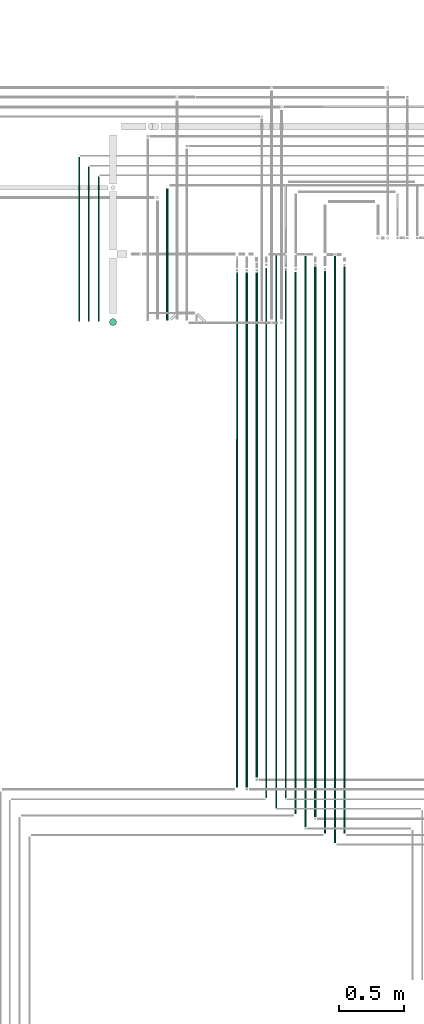
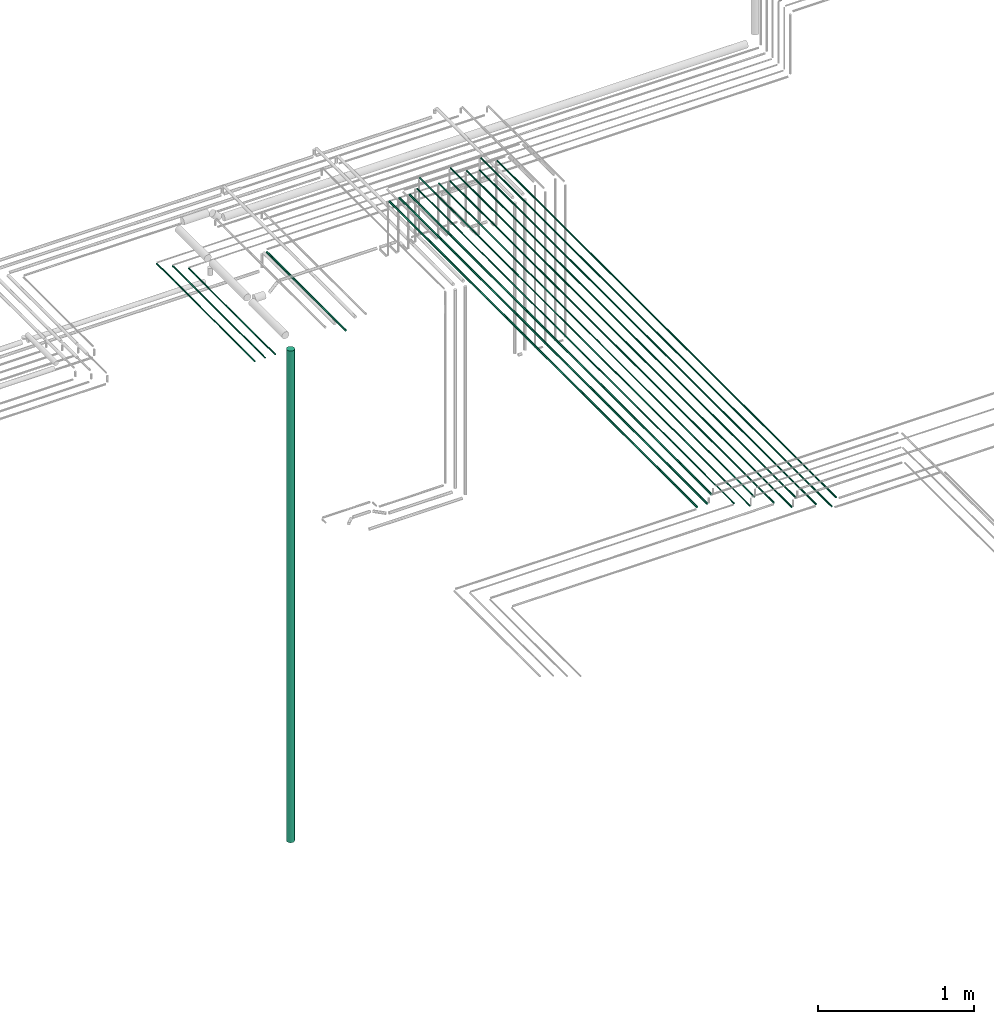
# One storey, part 24 of 65: 17 flow segments.
"""IFC2X3 building model written with IfcOpenShell, lengths in millimetres."""

from ifc_helpers import new_model, entity, si_unit, converted_unit, derived_unit, direction, frame, frame_2d, origin, origin_2d_with_axis, place, context, subcontext, project, spatial, circle, extrude, type_object, element, save


model = new_model("IFC2X3")

# Units and contexts
model_context = context("Model", 3, precision=0.01, world=origin(), true_north=direction((6.12303176911189e-17, 1.0)))
body_context = subcontext(model_context, "Body", "Model", "MODEL_VIEW")
ifc_project = project(units=[si_unit("LENGTHUNIT", "METRE", prefix="MILLI"), si_unit("AREAUNIT", "SQUARE_METRE"), si_unit("VOLUMEUNIT", "CUBIC_METRE"), converted_unit("PLANEANGLEUNIT", "DEGREE", entity("IfcRatioMeasure", 0.0174532925199433), si_unit("PLANEANGLEUNIT", "RADIAN"), dimensions=[0, 0, 0, 0, 0, 0, 0]), si_unit("MASSUNIT", "GRAM", prefix="KILO"), derived_unit("MASSDENSITYUNIT", [(si_unit("MASSUNIT", "GRAM", prefix="KILO"), 1), (si_unit("LENGTHUNIT", "METRE"), -3)]), derived_unit("MOMENTOFINERTIAUNIT", [(si_unit("LENGTHUNIT", "METRE"), 4)]), si_unit("TIMEUNIT", "SECOND"), si_unit("FREQUENCYUNIT", "HERTZ"), si_unit("THERMODYNAMICTEMPERATUREUNIT", "DEGREE_CELSIUS"), derived_unit("THERMALTRANSMITTANCEUNIT", [(si_unit("MASSUNIT", "GRAM", prefix="KILO"), 1), (si_unit("THERMODYNAMICTEMPERATUREUNIT", "KELVIN"), -1), (si_unit("TIMEUNIT", "SECOND"), -3)]), derived_unit("VOLUMETRICFLOWRATEUNIT", [(si_unit("LENGTHUNIT", "METRE"), 3), (si_unit("TIMEUNIT", "SECOND"), -1)]), derived_unit("MASSFLOWRATEUNIT", [(si_unit("MASSUNIT", "GRAM", prefix="KILO"), 1), (si_unit("TIMEUNIT", "SECOND"), -1)]), derived_unit("ROTATIONALFREQUENCYUNIT", [(si_unit("TIMEUNIT", "SECOND"), -1)]), si_unit("ELECTRICCURRENTUNIT", "AMPERE"), si_unit("ELECTRICVOLTAGEUNIT", "VOLT"), si_unit("POWERUNIT", "WATT"), si_unit("FORCEUNIT", "NEWTON", prefix="KILO"), si_unit("ILLUMINANCEUNIT", "LUX"), si_unit("LUMINOUSFLUXUNIT", "LUMEN"), si_unit("LUMINOUSINTENSITYUNIT", "CANDELA"), derived_unit("USERDEFINED", [(si_unit("MASSUNIT", "GRAM", prefix="KILO"), -1), (si_unit("LENGTHUNIT", "METRE"), -2), (si_unit("TIMEUNIT", "SECOND"), 3), (si_unit("LUMINOUSFLUXUNIT", "LUMEN"), 1)]), derived_unit("LINEARVELOCITYUNIT", [(si_unit("LENGTHUNIT", "METRE"), 1), (si_unit("TIMEUNIT", "SECOND"), -1)]), si_unit("PRESSUREUNIT", "PASCAL"), derived_unit("USERDEFINED", [(si_unit("LENGTHUNIT", "METRE"), -2), (si_unit("MASSUNIT", "GRAM", prefix="KILO"), 1), (si_unit("TIMEUNIT", "SECOND"), -2)]), derived_unit("LINEARFORCEUNIT", [(si_unit("MASSUNIT", "GRAM", prefix="KILO"), 1), (si_unit("LENGTHUNIT", "METRE"), 1), (si_unit("TIMEUNIT", "SECOND"), -2), (si_unit("LENGTHUNIT", "METRE"), -1)]), derived_unit("PLANARFORCEUNIT", [(si_unit("MASSUNIT", "GRAM", prefix="KILO"), 1), (si_unit("LENGTHUNIT", "METRE"), 1), (si_unit("TIMEUNIT", "SECOND"), -2), (si_unit("LENGTHUNIT", "METRE"), -2)])], contexts=[model_context])

# Site, building, storey
site_placement = place(None, frame((0.0, -0.00077364408347762, 0.0)))
site = spatial("IfcSite", under=ifc_project, at=site_placement, CompositionType="ELEMENT")
building_placement = place(site_placement, origin())
building = spatial("IfcBuilding", under=site, at=building_placement, CompositionType="ELEMENT")
storey_placement = place(building_placement, frame((0.0, 0.0, 19800.0)))
storey = spatial("IfcBuildingStorey", under=building, at=storey_placement, CompositionType="ELEMENT", Elevation=19800.0)

# Flow segments
pipe_segment_type = type_object("IfcPipeSegmentType", PredefinedType="NOTDEFINED")
flow_segment_1_placement = place(storey_placement, frame((65491.517459311, 7682.64840150688, 2540.9047277641)))
element("IfcFlowSegment", 1, at=flow_segment_1_placement, inside=storey, type_object=pipe_segment_type, context=body_context, shape_type="SweptSolid", body=[
    extrude(circle(Radius=7.5, at=frame_2d((-8.66293703438714e-12, 0.0), x_axis=(1.0, 0.0))), frame((9.09527223592286, 0.0, 9.09527223591419), z_axis=(0.0, 1.0, 0.0), x_axis=(1.0, 0.0, 0.0)), (0.0, 0.0, 1.0), 1011.22234040728),
])
flow_segment_2_placement = place(storey_placement, frame((64969.5166110417, 7676.14924977608, 2544.4047277641)))
element("IfcFlowSegment", 2, at=flow_segment_2_placement, inside=storey, type_object=pipe_segment_type, context=body_context, shape_type="SweptSolid", body=[
    extrude(circle(Radius=4.0, at=origin_2d_with_axis()), frame((5.59527223592365, 0.0, 5.59527223591499), z_axis=(0.0, 1.0, 0.0), x_axis=(1.0, 0.0, 0.0)), (0.0, 0.0, 1.0), 1108.30342170028),
])
flow_segment_3_placement = place(storey_placement, frame((64894.5166110417, 7676.14924977608, 2544.40472776409)))
element("IfcFlowSegment", 3, at=flow_segment_3_placement, inside=storey, type_object=pipe_segment_type, context=body_context, shape_type="SweptSolid", body=[
    extrude(circle(Radius=4.0, at=origin_2d_with_axis()), frame((5.59527223592365, 0.0, 5.59527223591499), z_axis=(0.0, 1.0, 0.0), x_axis=(1.0, 0.0, 0.0)), (0.0, 0.0, 1.0), 1183.30342170027),
])
flow_segment_4_placement = place(storey_placement, frame((64819.5166110417, 7676.14924977607, 2544.40472776409)))
element("IfcFlowSegment", 4, at=flow_segment_4_placement, inside=storey, type_object=pipe_segment_type, context=body_context, shape_type="SweptSolid", body=[
    extrude(circle(Radius=4.0, at=origin_2d_with_axis()), frame((5.59527223592365, 0.0, 5.59527223591499), z_axis=(0.0, 1.0, 0.0), x_axis=(1.0, 0.0, 0.0)), (0.0, 0.0, 1.0), 1258.30342170029),
])
flow_segment_5_placement = place(storey_placement, frame((66702.5166110418, 3753.41126264128, 3142.40472776409)))
element("IfcFlowSegment", 5, at=flow_segment_5_placement, inside=storey, type_object=pipe_segment_type, context=body_context, shape_type="SweptSolid", body=[
    extrude(circle(Radius=6.0, at=frame_2d((1.2128111848142e-10, 0.0), x_axis=(1.0, 0.0))), frame((7.59527223603582, 0.0, 7.59527223591454), z_axis=(0.0, 1.0, 0.0), x_axis=(-1.0, 0.0, 0.0)), (0.0, 0.0, 1.0), 4307.7379871348),
])
flow_segment_6_placement = place(storey_placement, frame((66777.5166110418, 3679.42540692289, 3142.40472776405)))
element("IfcFlowSegment", 6, at=flow_segment_6_placement, inside=storey, type_object=pipe_segment_type, context=body_context, shape_type="SweptSolid", body=[
    extrude(circle(Radius=6.0, at=origin_2d_with_axis()), frame((7.59527223591454, 0.0, 7.59527223591454), z_axis=(0.0, 1.0, 0.0), x_axis=(1.0, 0.0, 0.0)), (0.0, 0.0, 1.0), 4495.8511619809),
])
flow_segment_7_placement = place(storey_placement, frame((66852.5166110418, 3754.4254069229, 3142.40472776405)))
element("IfcFlowSegment", 7, at=flow_segment_7_placement, inside=storey, type_object=pipe_segment_type, context=body_context, shape_type="SweptSolid", body=[
    extrude(circle(Radius=6.0, at=origin_2d_with_axis()), frame((7.59527223591454, 0.0, 7.59527223591454), z_axis=(0.0, 1.0, 0.0), x_axis=(1.0, 0.0, 0.0)), (0.0, 0.0, 1.0), 4340.85116198088),
])
flow_segment_8_placement = place(storey_placement, frame((66477.5166110418, 3903.41126264128, 3142.40472776409)))
element("IfcFlowSegment", 8, at=flow_segment_8_placement, inside=storey, type_object=pipe_segment_type, context=body_context, shape_type="SweptSolid", body=[
    extrude(circle(Radius=6.0, at=frame_2d((1.2128111848142e-10, 0.0), x_axis=(1.0, 0.0))), frame((7.59527223603582, 0.0, 7.59527223591454), z_axis=(0.0, 1.0, 0.0), x_axis=(-1.0, 0.0, 0.0)), (0.0, 0.0, 1.0), 4147.7379871348),
])
flow_segment_9_placement = place(storey_placement, frame((66552.5166110418, 3803.41126264128, 3142.40472776403)))
element("IfcFlowSegment", 9, at=flow_segment_9_placement, inside=storey, type_object=pipe_segment_type, context=body_context, shape_type="SweptSolid", body=[
    extrude(circle(Radius=6.0, at=origin_2d_with_axis()), frame((7.59527223591454, 0.0, 7.59527223591454), z_axis=(0.0, 1.0, 0.0), x_axis=(1.0, 0.0, 0.0)), (0.0, 0.0, 1.0), 4371.86530626252),
])
flow_segment_10_placement = place(storey_placement, frame((66627.5166110418, 3878.41126264128, 3142.40472776403)))
element("IfcFlowSegment", 10, at=flow_segment_10_placement, inside=storey, type_object=pipe_segment_type, context=body_context, shape_type="SweptSolid", body=[
    extrude(circle(Radius=6.0, at=origin_2d_with_axis()), frame((7.59527223591454, 0.0, 7.59527223591454), z_axis=(0.0, 1.0, 0.0), x_axis=(1.0, 0.0, 0.0)), (0.0, 0.0, 1.0), 4216.86530626251),
])
flow_segment_11_placement = place(storey_placement, frame((66404.5166110415, 4024.41126264127, 3144.40472776405)))
element("IfcFlowSegment", 11, at=flow_segment_11_placement, inside=storey, type_object=pipe_segment_type, context=body_context, shape_type="SweptSolid", body=[
    extrude(circle(Radius=4.0, at=origin_2d_with_axis()), frame((5.59527223592365, 0.0, 5.59527223591499), z_axis=(0.0, 1.0, 0.0), x_axis=(1.0, 0.0, 0.0)), (0.0, 0.0, 1.0), 4040.73798713481),
])
flow_segment_12_placement = place(storey_placement, frame((66329.5166110417, 3949.41126264127, 3144.40472776403)))
element("IfcFlowSegment", 12, at=flow_segment_12_placement, inside=storey, type_object=pipe_segment_type, context=body_context, shape_type="SweptSolid", body=[
    extrude(circle(Radius=4.0, at=origin_2d_with_axis()), frame((5.59527223591499, 0.0, 5.59527223591499), z_axis=(0.0, 1.0, 0.0), x_axis=(1.0, 0.0, 0.0)), (0.0, 0.0, 1.0), 4229.86530626252),
])
flow_segment_13_placement = place(storey_placement, frame((66254.5166110417, 4024.41126264129, 3144.40472776409)))
element("IfcFlowSegment", 13, at=flow_segment_13_placement, inside=storey, type_object=pipe_segment_type, context=body_context, shape_type="SweptSolid", body=[
    extrude(circle(Radius=4.0, at=frame_2d((8.66293703438714e-12, 0.0), x_axis=(1.0, 0.0))), frame((5.59527223591499, 0.0, 5.59527223591499), z_axis=(0.0, 1.0, 0.0), x_axis=(-1.0, 0.0, 0.0)), (0.0, 0.0, 1.0), 4058.86530626249),
])
flow_segment_14_placement = place(storey_placement, frame((66176.0166110417, 4182.41126264127, 3140.90472776403)))
element("IfcFlowSegment", 14, at=flow_segment_14_placement, inside=storey, type_object=pipe_segment_type, context=body_context, shape_type="SweptSolid", body=[
    extrude(circle(Radius=7.5, at=origin_2d_with_axis()), frame((9.09527223591419, 0.0, 9.09527223591419), z_axis=(0.0, 1.0, 0.0), x_axis=(1.0, 0.0, 0.0)), (0.0, 0.0, 1.0), 3867.00314439781),
])
flow_segment_15_placement = place(storey_placement, frame((66101.0166110417, 4107.41126264129, 3140.90472776409)))
element("IfcFlowSegment", 15, at=flow_segment_15_placement, inside=storey, type_object=pipe_segment_type, context=body_context, shape_type="SweptSolid", body=[
    extrude(circle(Radius=7.5, at=origin_2d_with_axis()), frame((9.09527223591419, 0.0, 9.09527223591419), z_axis=(0.0, 1.0, 0.0), x_axis=(-1.0, 0.0, 0.0)), (0.0, 0.0, 1.0), 3942.00314439779),
])
flow_segment_16_placement = place(storey_placement, frame((66026.0166110417, 4107.41126264129, 3140.90472776409)))
element("IfcFlowSegment", 16, at=flow_segment_16_placement, inside=storey, type_object=pipe_segment_type, context=body_context, shape_type="SweptSolid", body=[
    extrude(circle(Radius=7.5, at=frame_2d((8.66293703438714e-12, 0.0), x_axis=(1.0, 0.0))), frame((9.09527223592286, 0.0, 9.09527223591419), z_axis=(0.0, 1.0, 0.0), x_axis=(-1.0, 0.0, 0.0)), (0.0, 0.0, 1.0), 3942.00314439778),
])
flow_segment_17_placement = place(storey_placement, frame((65056.5166110417, 7641.55397753964, -1285.0)))
element("IfcFlowSegment", 17, at=flow_segment_17_placement, inside=storey, type_object=pipe_segment_type, context=body_context, shape_type="SweptSolid", body=[
    extrude(circle(Radius=27.0, at=origin_2d_with_axis()), frame((28.5952722359184, 28.5952722359163, 0.0), z_axis=(0.0, 0.0, 1.0), x_axis=(-1.0, 0.0, 0.0)), (0.0, 0.0, 1.0), 3845.00000000004),
])

save(model, "model.ifc")
